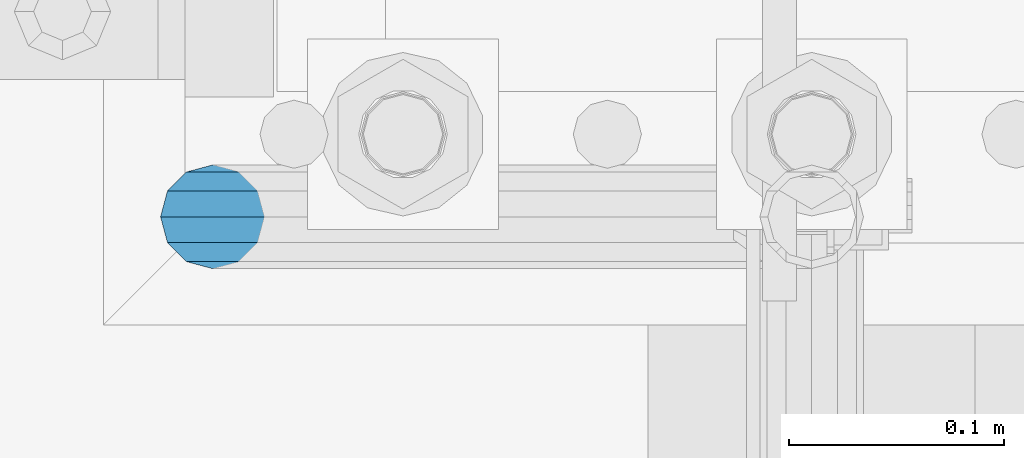
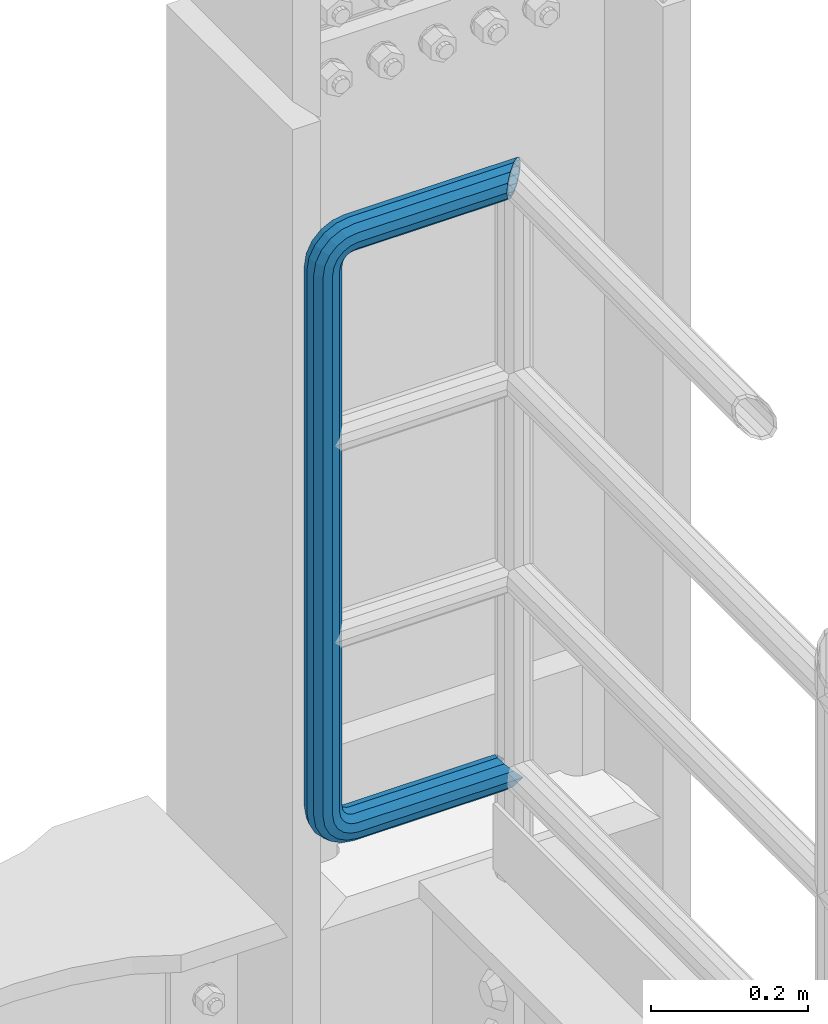
# One storey, part 1072 of 1876: 1 beam, 1 element without a shape of its own.
"""IFC2X3 building model written with IfcOpenShell, lengths in millimetres."""

from ifc_helpers import new_model, si_unit, frame, origin_with_axes, place, context, subcontext, project, spatial, faceted_brep, material, type_object, element, aggregate, save


model = new_model("IFC2X3")

# Units and contexts
model_context = context("Model", 3, precision=1e-05, world=origin_with_axes())
body_context = subcontext(model_context, "Body", "Model", "MODEL_VIEW")
ifc_project = project(units=[si_unit("LENGTHUNIT", "METRE", prefix="MILLI"), si_unit("AREAUNIT", "SQUARE_METRE"), si_unit("VOLUMEUNIT", "CUBIC_METRE"), si_unit("MASSUNIT", "GRAM", prefix="KILO"), si_unit("TIMEUNIT", "SECOND"), si_unit("PLANEANGLEUNIT", "RADIAN"), si_unit("SOLIDANGLEUNIT", "STERADIAN"), si_unit("THERMODYNAMICTEMPERATUREUNIT", "DEGREE_CELSIUS"), si_unit("LUMINOUSINTENSITYUNIT", "LUMEN")], contexts=[model_context])

# Site, building, storey
site_placement = place(None, origin_with_axes())
site = spatial("IfcSite", under=ifc_project, at=site_placement, CompositionType="ELEMENT")
building_placement = place(site_placement, origin_with_axes())
building = spatial("IfcBuilding", under=site, at=building_placement, Name="Undefined", CompositionType="ELEMENT")
storey_placement = place(building_placement, origin_with_axes())
storey = spatial("IfcBuildingStorey", under=building, at=storey_placement, Name="Undefined", CompositionType="ELEMENT", Elevation=0.0)

# Assembly, beam
assembly_placement = place(storey_placement, origin_with_axes())
assembly = element("IfcElementAssembly", 1, at=assembly_placement, inside=storey, Name="RAIL", AssemblyPlace="NOTDEFINED", PredefinedType="RIGID_FRAME")
ifc_material = material()
beam_type = type_object("IfcBeamType", Name="PIPE1-1/2SCH40", PredefinedType="NOTDEFINED")
beam_placement = place(assembly_placement, frame((7619.99999999999, 13499.7063, 14385.925), z_axis=(0.0, 0.0, 1.0), x_axis=(-1.0, 0.0, 0.0)))
beam = element("IfcBeam", 2, at=beam_placement, type_object=beam_type, material=ifc_material, Name="RAIL", ObjectType="PIPE1-1/2SCH40", context=body_context, shape_type="Brep", body=[
    faceted_brep([(1.20714750983051e-12, 24.1299999999974, -914.399963378906), (12.0650000000014, 20.8971929933159, -926.464963378905), (12.0650000000014, 20.8971929933177, -902.334963378908), (12.0650000000014, -20.8971929933195, -902.334963378908), (12.0650000000014, -20.8971929933195, -926.464963378905), (1.52133659548828e-12, -24.130000000001, -914.399963378906), (20.8971929933199, -12.0650000000023, -893.502770385589), (20.8971929933199, -12.0650000000005, -898.533841947723), (15.2545715621378, -17.7076214311819, -904.176463378906), (12.5151929933181, -20.4470000000019, -914.399963378906), (15.2545715621376, -17.7076214311819, -924.623463378906), (20.8971929933199, -12.0650000000005, -930.26608481009), (20.8971929933199, -12.0650000000023, -935.297156372224), (24.1300000000014, -1.81898940354586e-12, -934.846963378906), (24.1300000000014, -1.81898940354586e-12, -938.529963378907), (21.3906214311813, -10.2235000000019, -932.107584810088), (21.3906214311823, 10.2234999999982, -932.107584810088), (20.8971929933199, 12.0650000000005, -930.266084810086), (20.8971929933199, 12.0649999999987, -935.297156372224), (15.2545715621413, 17.7076214311783, -924.623463378906), (12.5151929933216, 20.4469999999983, -914.399963378906), (15.2545715621411, 17.7076214311783, -904.176463378906), (20.8971929933199, 12.0650000000005, -898.533841947727), (20.8971929933199, 12.0649999999987, -893.502770385589), (21.3906214311822, 10.2234999999982, -896.692341947724), (24.1300000000014, 0.0, -893.952963378906), (24.1300000000014, 0.0, -890.269963378905), (21.3906214311814, -10.2235000000019, -896.692341947724), (241.299995422363, 20.8971929933177, -12.0649999999987), (241.299995422363, 24.1299999999992, 0.0), (253.073542436527, 24.1299999999992, -1.86474665447167), (249.345252399393, 20.8971929933177, -13.3392435235728), (241.299995422363, 12.0650000000005, -20.8971929933177), (246.615954666858, 12.0650000000005, -21.7391582230448), (241.299995422363, 0.0, -24.130000000001), (245.616962362259, 0.0, -24.8137403926739), (241.299995422363, -12.0650000000005, -20.8971929933177), (246.615954666858, -12.0650000000005, -21.7391582230448), (241.299995422363, -20.8971929933177, -12.0649999999987), (249.345252399393, -20.8971929933177, -13.3392435235728), (241.299995422363, -24.1299999999992, 0.0), (253.073542436527, -24.1299999999992, -1.86474665447167), (241.299995422363, -20.8971929933177, 12.0649999999987), (256.801832473661, -20.8971929933177, 9.60975021462946), (241.299995422363, -12.0650000000005, 20.8971929933177), (259.531130206197, -12.0650000000005, 18.0096649141014), (241.299995422363, 0.0, 24.130000000001), (260.530122510796, 0.0, 21.084247083727), (241.299995422363, 12.0650000000005, 20.8971929933177), (259.531130206197, 12.0650000000005, 18.0096649141014), (241.299995422363, 20.8971929933177, 12.0649999999987), (256.801832473661, 20.8971929933177, 9.60975021462946), (291.464993896486, -20.8971929933177, -38.0999984741211), (279.399993896484, -24.1299999999992, -38.0999984741211), (279.399993896484, -24.1299999999992, -876.299964904785), (291.464993896484, -20.8971929933177, -876.299964904785), (267.334993896485, -20.8971929933177, -38.0999984741211), (267.334993896484, -20.8971929933177, -876.299964904785), (258.502800903167, -12.0650000000005, -38.0999984741211), (258.502800903166, -12.0650000000005, -876.299964904785), (255.269993896485, 0.0, -38.0999984741211), (255.269993896484, 0.0, -876.299964904785), (258.502800903167, 12.0650000000005, -38.0999984741211), (258.502800903166, 12.0650000000005, -876.299964904785), (267.334993896485, 20.8971929933177, -38.0999984741211), (267.334993896484, 20.8971929933177, -876.299964904785), (279.399993896485, 24.1299999999992, -38.0999984741211), (279.399993896484, 24.1299999999992, -876.299964904785), (291.464993896486, 20.8971929933177, -38.0999984741211), (291.464993896484, 20.8971929933177, -876.299964904785), (300.297186889804, 12.0650000000005, -38.0999984741211), (300.297186889803, 12.0650000000005, -876.299964904785), (303.529993896486, 0.0, -38.0999984741211), (303.529993896484, 0.0, -876.299964904785), (300.297186889804, -12.0650000000005, -38.0999984741211), (300.297186889803, -12.0650000000005, -876.299964904785), (297.409658810584, -12.0650000000005, -894.531099688622), (300.484240980214, 0.0, -895.53009199322), (297.409658810584, 12.0650000000005, -894.531099688622), (289.009744111112, 20.8971929933177, -891.801801956084), (277.535247242011, 24.1299999999992, -888.073511918952), (266.06075037291, 20.8971929933177, -884.345221881817), (257.660835673438, 12.0650000000005, -881.615924149282), (254.586253503809, 0.0, -880.616931844681), (257.660835673438, -12.0650000000005, -881.615924149282), (266.06075037291, -20.8971929933177, -884.345221881817), (277.535247242011, -24.130000000001, -888.073511918952), (289.009744111112, -20.8971929933195, -891.801801956084), (241.299995422363, -20.8971929933195, -902.334963378908), (241.299995422363, -12.0650000000005, -893.502770385589), (241.299995422363, -24.130000000001, -914.399963378906), (241.299995422364, -20.8971929933195, -926.464963378909), (241.299995422364, -12.0650000000005, -935.297156372228), (241.299995422364, -1.81898940354586e-12, -938.529963378911), (241.299995422364, 12.0649999999987, -935.297156372228), (241.299995422364, 20.8971929933177, -926.464963378909), (241.299995422364, 24.1299999999992, -914.39996337891), (241.299995422363, 20.8971929933177, -902.334963378908), (241.299995422363, 12.0649999999987, -893.502770385589), (241.299995422363, 0.0, -890.269963378909), (245.61696236226, 0.0, -889.586222986232), (246.615954666859, -12.0650000000005, -892.660805155861), (246.615954666859, 12.0649999999987, -892.660805155861), (249.345252399395, 20.8971929933177, -901.060719855333), (253.07354243653, 24.1299999999992, -912.535216724435), (256.801832473666, 20.8971929933177, -924.009713593536), (259.531130206202, 12.0649999999987, -932.409628293008), (260.530122510801, 0.0, -935.484210462637), (259.531130206201, -12.0650000000005, -932.409628293008), (256.801832473666, -20.8971929933195, -924.009713593536), (253.07354243653, -24.130000000001, -912.535216724435), (249.345252399395, -20.8971929933195, -901.060719855333), (251.411550782037, -12.0650000000005, -890.21732688968), (256.602983568912, -20.8971929933195, -897.362721118872), (249.511354500001, 0.0, -887.601931081743), (251.411550782037, 12.0650000000005, -890.21732688968), (256.602983568912, 20.8971929933177, -897.362721118872), (263.694612637823, 24.1299999999992, -907.123511156005), (270.786241706733, 20.8971929933177, -916.884301193139), (275.977674493594, 12.0649999999987, -924.029695422345), (277.877870775644, 0.0, -926.645091230272), (275.977674493608, -12.0650000000005, -924.029695422334), (270.786241706733, -20.8971929933195, -916.884301193139), (263.694612637823, -24.130000000001, -907.123511156005), (262.362751636451, -20.8971929933195, -891.602953051333), (272.123541673585, -24.130000000001, -898.694582120243), (255.217357407258, -12.0650000000005, -886.411520264461), (252.601961599318, 0.0, -884.511323982424), (255.217357407258, 12.0650000000005, -886.411520264461), (262.362751636451, 20.8971929933177, -891.602953051333), (272.123541673585, 24.1299999999992, -898.694582120243), (281.884331710718, 20.8971929933177, -905.786211189152), (289.029725939912, 12.0650000000005, -910.977643976028), (291.645121747852, 0.0, -912.877840258065), (289.029725939912, -12.0650000000005, -910.977643976028), (281.884331710718, -20.8971929933195, -905.786211189152), (289.009744111112, -20.8971929933177, -22.5981614228222), (297.409658810584, -12.0650000000005, -19.8688636902843), (277.535247242011, -24.1299999999992, -26.3264514599541), (266.060750372911, -20.8971929933177, -30.0547414970897), (257.660835673439, -12.0650000000005, -32.7840392296275), (254.58625350381, 0.0, -33.7830315342253), (257.660835673439, 12.0650000000005, -32.7840392296275), (266.060750372911, 20.8971929933177, -30.0547414970897), (277.535247242011, 24.1299999999992, -26.3264514599541), (289.009744111112, 20.8971929933177, -22.5981614228222), (297.409658810584, 12.0650000000005, -19.8688636902843), (300.484240980213, 0.0, -18.8698713856866), (289.029725939909, -12.0650000000005, -3.42231940287456), (291.645121747848, 0.0, -1.52212312084157), (281.884331710716, -20.8971929933177, -8.61375218975081), (272.123541673583, -24.1299999999992, -15.7053812586601), (262.362751636451, -20.8971929933177, -22.7970103275729), (255.217357407257, -12.0650000000005, -27.9884431144455), (252.601961599318, 0.0, -29.8886393964822), (255.217357407257, 12.0650000000005, -27.9884431144455), (262.362751636451, 20.8971929933177, -22.7970103275729), (272.123541673583, 24.1299999999992, -15.7053812586601), (281.884331710716, 20.8971929933177, -8.61375218975081), (289.029725939909, 12.0650000000005, -3.42231940287456), (277.877870775642, 0.0, 12.2451278513654), (275.977674493607, 12.0650000000005, 9.62973204342416), (275.977674493607, -12.0650000000005, 9.62973204342416), (270.786241706732, -20.8971929933177, 2.48433781423228), (263.694612637822, -24.1299999999992, -7.27645222290084), (256.602983568912, -20.8971929933177, -17.037242260034), (251.411550782037, -12.0650000000005, -24.1826364892258), (249.511354500002, 0.0, -26.7980322971671), (251.411550782037, 12.0650000000005, -24.1826364892258), (256.602983568912, 20.8971929933177, -17.037242260034), (263.694612637822, 24.1299999999992, -7.27645222290084), (270.786241706732, 20.8971929933177, 2.48433781423228), (24.1300000000047, 24.1299999999992, 0.0), (20.8971929933232, 20.8971929933177, 12.0649999999987), (12.0650000000041, 12.0650000000005, 20.8971929933177), (-1.45519152283669e-11, 0.0, 24.130000000001), (-12.0649999999951, -12.0650000000005, 20.8971929933177), (-20.8971929933141, -20.8971929933177, 12.0649999999987), (0.0, -24.1299999999992, 0.0), (-24.1299999999956, -24.1299999999992, 0.0), (-12.0650000000096, -20.8971929933177, -12.0649999999987), (12.0650000000064, -20.8971929933177, -12.0649999999987), (-20.8971929933141, -20.8971929933177, -12.0649999999987), (-12.0649999999951, -12.0650000000005, -20.8971929933177), (20.8971929933249, -12.0650000000005, -20.8971929933177), (-16.481093238739, -16.4810932387427, -16.4810997545756), (24.1300000000063, 0.0, -24.130000000001), (-1.45519152283669e-11, 0.0, -24.130000000001), (20.8971929933249, 12.0650000000005, -20.8971929933177), (12.0650000000041, 12.0650000000005, -20.8971929933177), (20.8971929933232, 20.8971929933177, -12.0649999999987), (16.481099754581, 16.4810997545774, -16.4810932387409), (241.299995422363, -17.7076214311801, 10.2235000000001), (241.299995422363, -20.4470000000001, 0.0), (-20.4469999999956, -20.4470000000001, 0.0), (-17.7076214311755, -17.7076214311801, 10.2235000000001), (241.299995422363, -17.7076214311801, -10.2235000000001), (-17.7076214311755, -17.7076214311801, -10.2235000000001), (241.299995422363, -10.2235000000001, -17.7076214311819), (-10.2234999999955, -10.2235000000001, -17.7076214311819), (241.299995422363, 0.0, -20.4470000000001), (-1.45519152283669e-11, 0.0, -20.4470000000001), (241.299995422363, 10.2235000000001, -17.7076214311819), (10.2235000000046, 10.2235000000001, -17.7076214311819), (241.299995422363, 17.7076214311801, -10.2235000000001), (17.7076214311846, 17.7076214311801, -10.2235000000001), (241.299995422363, 20.4470000000001, 0.0), (20.4470000000047, 20.4470000000001, 0.0), (241.299995422363, 0.0, 20.4470000000001), (241.299995422363, -10.2235000000001, 17.7076214311819), (-10.2234999999955, -10.2235000000001, 17.7076214311819), (-1.45519152283669e-11, 0.0, 20.4470000000001), (241.299995422363, 10.2235000000001, 17.7076214311819), (10.2235000000046, 10.2235000000001, 17.7076214311819), (241.299995422363, 17.7076214311801, 10.2235000000001), (17.7076214311846, 17.7076214311801, 10.2235000000001), (258.545498388721, -10.2235000000001, 14.9762020957387), (256.23277767852, -17.7076214311801, 7.85837963987069), (253.073542436527, -20.4470000000001, -1.86474665447167), (249.914307194535, -17.7076214311801, -11.5878729488177), (247.601586484334, -10.2235000000001, -18.7056954046857), (246.755071952542, 0.0, -21.31099924316), (247.601586484334, 10.2235000000001, -18.7056954046857), (249.914307194535, 17.7076214311801, -11.5878729488177), (253.073542436527, 20.4470000000001, -1.86474665447167), (256.23277767852, 17.7076214311801, 7.85837963987069), (258.545498388721, 10.2235000000001, 14.9762020957387), (259.392012920513, 0.0, 17.5815059342131), (275.713057691449, 0.0, 9.26551826108334), (274.10289136825, -10.2235000000001, 7.04931444488102), (274.10289136825, 10.2235000000001, 7.04931444488102), (269.703835164635, 17.7076214311801, 0.994533019089431), (263.694612637822, 20.4470000000001, -7.27645222290084), (257.685390111009, 17.7076214311801, -15.5474374648911), (253.286333907394, 10.2235000000001, -21.6022188906827), (251.676167584195, 0.0, -23.818422706885), (253.286333907394, -10.2235000000001, -21.6022188906827), (257.685390111009, -17.7076214311801, -15.5474374648911), (263.694612637822, -20.4470000000001, -7.27645222290084), (269.703835164635, -17.7076214311801, 0.994533019089431), (286.449308341364, -10.2235000000001, -5.29710252823133), (280.394526915574, -17.7076214311801, -9.69615873184739), (288.665512157566, 0.0, -3.68693620503473), (286.449308341364, 10.2235000000001, -5.29710252823133), (280.394526915574, 17.7076214311801, -9.69615873184739), (272.123541673583, 20.4470000000001, -15.7053812586601), (263.852556431592, 17.7076214311801, -21.7146037854764), (257.797775005802, 10.2235000000001, -26.1136599890888), (255.581571189601, 0.0, -27.723826312289), (257.797775005802, -10.2235000000001, -26.1136599890888), (263.852556431592, -17.7076214311801, -21.7146037854764), (272.123541673583, -20.4470000000001, -15.7053812586601), (287.258373536355, -17.7076214311801, -23.1672162179639), (277.535247242011, -20.4470000000001, -26.3264514599541), (294.376195992223, -10.2235000000001, -20.8544955077632), (296.981499830698, 0.0, -20.00798097597), (294.376195992223, 10.2235000000001, -20.8544955077632), (287.258373536355, 17.7076214311801, -23.1672162179639), (277.535247242011, 20.4470000000001, -26.3264514599541), (267.812120947668, 17.7076214311801, -29.485686701948), (260.6942984918, 10.2235000000001, -31.7984074121487), (258.088994653325, 0.0, -32.6449219439419), (260.6942984918, -10.2235000000001, -31.7984074121487), (267.812120947668, -17.7076214311801, -29.485686701948), (279.399993896484, -20.4470000000001, -38.0999984741211), (269.176493896485, -17.7076214311801, -38.0999984741211), (289.623493896486, -17.7076214311801, -38.0999984741211), (297.107615327666, -10.2235000000001, -38.0999984741211), (299.846993896486, 0.0, -38.0999984741211), (297.107615327666, 10.2235000000001, -38.0999984741211), (289.623493896486, 17.7076214311801, -38.0999984741211), (279.399993896485, 20.4470000000001, -38.0999984741211), (269.176493896485, 17.7076214311801, -38.0999984741211), (261.692372465305, 10.2235000000001, -38.0999984741211), (258.952993896485, 0.0, -38.0999984741211), (261.692372465305, -10.2235000000001, -38.0999984741211), (269.176493896484, -17.7076214311801, -876.299964904785), (261.692372465304, -10.2235000000001, -876.299964904785), (258.952993896484, 0.0, -876.299964904785), (261.692372465304, 10.2235000000001, -876.299964904785), (269.176493896484, 17.7076214311801, -876.299964904785), (279.399993896484, 20.4470000000001, -876.299964904785), (289.623493896484, 17.7076214311801, -876.299964904785), (297.107615327665, 10.2235000000001, -876.299964904785), (299.846993896484, 0.0, -876.299964904785), (297.107615327665, -10.2235000000001, -876.299964904785), (289.623493896484, -17.7076214311801, -876.299964904785), (279.399993896484, -20.4470000000001, -876.299964904785), (277.535247242011, -20.4470000000001, -888.073511918952), (267.812120947667, -17.7076214311801, -884.914276676958), (260.694298491799, -10.2235000000001, -882.601555966758), (258.088994653324, 0.0, -881.755041434964), (260.694298491799, 10.2235000000001, -882.601555966758), (267.812120947668, 17.7076214311801, -884.914276676958), (277.535247242011, 20.4470000000001, -888.073511918952), (287.258373536355, 17.7076214311801, -891.232747160942), (294.376195992223, 10.2235000000001, -893.545467871143), (296.981499830699, 0.0, -894.391982402936), (294.376195992223, -10.2235000000001, -893.545467871143), (287.258373536355, -17.7076214311801, -891.232747160942), (280.394526915577, -17.7076214311801, -904.703804647055), (272.123541673585, -20.4470000000001, -898.694582120243), (286.449308341367, -10.2235000000001, -909.102860850671), (288.665512157569, 0.0, -910.713027173868), (286.449308341367, 10.2235000000001, -909.102860850671), (280.394526915577, 17.7076214311801, -904.703804647055), (272.123541673585, 20.4470000000001, -898.694582120243), (263.852556431593, 17.7076214311801, -892.68535959343), (257.797775005802, 10.2235000000001, -888.286303389817), (255.581571189601, 0.0, -886.676137066617), (257.797775005802, -10.2235000000001, -888.286303389817), (263.852556431593, -17.7076214311801, -892.68535959343), (263.694612637823, -20.4470000000001, -907.123511156005), (257.685390111009, -17.7076214311801, -898.852525914015), (269.703835164636, -17.7076214311801, -915.394496397999), (274.102891368238, -10.2235000000001, -921.449277823798), (275.71305769145, 0.0, -923.66548163999), (274.102891368251, 10.2235000000001, -921.449277823787), (269.703835164636, 17.7076214311801, -915.394496397999), (263.694612637823, 20.4470000000001, -907.123511156005), (257.685390111009, 17.7076214311801, -898.852525914015), (253.286333907394, 10.2235000000001, -892.797744488227), (251.676167584195, 0.0, -890.581540672025), (253.286333907394, -10.2235000000001, -892.797744488227), (249.914307194537, -17.7076214311801, -902.812090430092), (247.601586484335, -10.2235000000001, -895.694267974224), (253.07354243653, -20.4470000000001, -912.535216724435), (256.232777678524, -17.7076214311819, -922.258343018777), (258.545498388725, -10.2235000000001, -929.376165474645), (259.392012920517, 0.0, -931.981469313119), (258.545498388725, 10.2235000000001, -929.376165474645), (256.232777678524, 17.7076214311801, -922.258343018777), (253.07354243653, 20.4470000000001, -912.535216724435), (249.914307194537, 17.7076214311801, -902.812090430092), (247.601586484335, 10.2235000000001, -895.694267974224), (246.755071952543, 0.0, -893.088964135746), (241.299995422363, -10.2235000000001, -896.692341947728), (241.299995422363, 0.0, -893.95296337891), (241.299995422363, -17.7076214311819, -904.17646337891), (241.299995422363, -20.4470000000001, -914.399963378906), (241.299995422364, -17.7076214311819, -924.62346337891), (241.299995422364, -10.2235000000001, -932.107584810088), (241.299995422364, -1.81898940354586e-12, -934.84696337891), (241.299995422364, 10.2234999999982, -932.107584810088), (241.299995422364, 17.7076214311801, -924.62346337891), (241.299995422364, 20.4470000000001, -914.39996337891), (241.299995422363, 17.7076214311801, -904.17646337891), (241.299995422363, 10.2235000000001, -896.692341947728)], [[[0, 1, 2]], [[3, 4, 5]], [[6, 7, 8, 9, 10, 11, 12, 4, 3]], [[13, 14, 12, 11, 15]], [[16, 17, 18, 14, 13]], [[2, 1, 18, 17, 19, 20, 21, 22, 23]], [[23, 22, 24, 25, 26]], [[26, 25, 27, 7, 6]], [[28, 29, 30, 31]], [[32, 28, 31, 33]], [[34, 32, 33, 35]], [[36, 34, 35, 37]], [[38, 36, 37, 39]], [[40, 38, 39, 41]], [[42, 40, 41, 43]], [[44, 42, 43, 45]], [[46, 44, 45, 47]], [[48, 46, 47, 49]], [[50, 48, 49, 51]], [[52, 53, 54, 55]], [[53, 56, 57, 54]], [[56, 58, 59, 57]], [[58, 60, 61, 59]], [[60, 62, 63, 61]], [[62, 64, 65, 63]], [[64, 66, 67, 65]], [[66, 68, 69, 67]], [[68, 70, 71, 69]], [[70, 72, 73, 71]], [[72, 74, 75, 73]], [[73, 75, 76, 77]], [[71, 73, 77, 78]], [[69, 71, 78, 79]], [[67, 69, 79, 80]], [[65, 67, 80, 81]], [[63, 65, 81, 82]], [[61, 63, 82, 83]], [[59, 61, 83, 84]], [[57, 59, 84, 85]], [[54, 57, 85, 86]], [[55, 54, 86, 87]], [[88, 89, 6, 3]], [[90, 88, 3, 5]], [[91, 90, 5, 4]], [[92, 91, 4, 12]], [[93, 92, 12, 14]], [[94, 93, 14, 18]], [[95, 94, 18, 1]], [[96, 95, 1, 0]], [[97, 96, 0, 2]], [[98, 97, 2, 23]], [[99, 98, 23, 26]], [[89, 99, 26, 6]], [[100, 99, 89, 101]], [[102, 98, 99, 100]], [[103, 97, 98, 102]], [[104, 96, 97, 103]], [[105, 95, 96, 104]], [[106, 94, 95, 105]], [[107, 93, 94, 106]], [[108, 92, 93, 107]], [[109, 91, 92, 108]], [[110, 90, 91, 109]], [[111, 88, 90, 110]], [[101, 89, 88, 111]], [[112, 101, 111, 113]], [[114, 100, 101, 112]], [[115, 102, 100, 114]], [[116, 103, 102, 115]], [[117, 104, 103, 116]], [[118, 105, 104, 117]], [[119, 106, 105, 118]], [[120, 107, 106, 119]], [[121, 108, 107, 120]], [[122, 109, 108, 121]], [[123, 110, 109, 122]], [[113, 111, 110, 123]], [[124, 113, 123, 125]], [[126, 112, 113, 124]], [[127, 114, 112, 126]], [[128, 115, 114, 127]], [[129, 116, 115, 128]], [[130, 117, 116, 129]], [[131, 118, 117, 130]], [[132, 119, 118, 131]], [[133, 120, 119, 132]], [[134, 121, 120, 133]], [[135, 122, 121, 134]], [[125, 123, 122, 135]], [[86, 125, 135, 87]], [[85, 124, 125, 86]], [[84, 126, 124, 85]], [[83, 127, 126, 84]], [[82, 128, 127, 83]], [[81, 129, 128, 82]], [[80, 130, 129, 81]], [[79, 131, 130, 80]], [[78, 132, 131, 79]], [[77, 133, 132, 78]], [[76, 134, 133, 77]], [[87, 135, 134, 76]], [[75, 55, 87, 76]], [[74, 52, 55, 75]], [[136, 52, 74, 137]], [[138, 53, 52, 136]], [[139, 56, 53, 138]], [[140, 58, 56, 139]], [[141, 60, 58, 140]], [[142, 62, 60, 141]], [[143, 64, 62, 142]], [[144, 66, 64, 143]], [[145, 68, 66, 144]], [[146, 70, 68, 145]], [[147, 72, 70, 146]], [[137, 74, 72, 147]], [[148, 137, 147, 149]], [[150, 136, 137, 148]], [[151, 138, 136, 150]], [[152, 139, 138, 151]], [[153, 140, 139, 152]], [[154, 141, 140, 153]], [[155, 142, 141, 154]], [[156, 143, 142, 155]], [[157, 144, 143, 156]], [[158, 145, 144, 157]], [[159, 146, 145, 158]], [[149, 147, 146, 159]], [[160, 149, 159, 161]], [[162, 148, 149, 160]], [[163, 150, 148, 162]], [[164, 151, 150, 163]], [[165, 152, 151, 164]], [[166, 153, 152, 165]], [[167, 154, 153, 166]], [[168, 155, 154, 167]], [[169, 156, 155, 168]], [[170, 157, 156, 169]], [[171, 158, 157, 170]], [[161, 159, 158, 171]], [[49, 161, 171, 51]], [[47, 160, 161, 49]], [[45, 162, 160, 47]], [[43, 163, 162, 45]], [[41, 164, 163, 43]], [[39, 165, 164, 41]], [[37, 166, 165, 39]], [[35, 167, 166, 37]], [[33, 168, 167, 35]], [[31, 169, 168, 33]], [[30, 170, 169, 31]], [[51, 171, 170, 30]], [[29, 50, 51, 30]], [[50, 29, 172, 173]], [[48, 50, 173, 174]], [[46, 48, 174, 175]], [[44, 46, 175, 176]], [[42, 44, 176, 177]], [[178, 40, 42, 177, 179]], [[180, 181, 38, 40, 178, 179, 182]], [[183, 184, 36, 38, 181, 180, 182, 185]], [[186, 34, 36, 184, 183, 187]], [[188, 32, 34, 186, 187, 189]], [[190, 28, 32, 188, 189, 191]], [[29, 28, 190, 172]], [[192, 193, 194, 195]], [[193, 196, 197, 194]], [[196, 198, 199, 197]], [[198, 200, 201, 199]], [[200, 202, 203, 201]], [[202, 204, 205, 203]], [[204, 206, 207, 205]], [[208, 209, 210, 211]], [[212, 208, 211, 213]], [[214, 212, 213, 215]], [[206, 214, 215, 207]], [[191, 189, 187, 183, 185, 182, 179, 177, 176, 175, 174, 173, 172, 190], [213, 211, 210, 195, 194, 197, 199, 201, 203, 205, 207, 215]], [[209, 192, 195, 210]], [[192, 209, 216, 217]], [[193, 192, 217, 218]], [[196, 193, 218, 219]], [[198, 196, 219, 220]], [[200, 198, 220, 221]], [[202, 200, 221, 222]], [[204, 202, 222, 223]], [[206, 204, 223, 224]], [[214, 206, 224, 225]], [[212, 214, 225, 226]], [[208, 212, 226, 227]], [[209, 208, 227, 216]], [[227, 228, 229, 216]], [[226, 230, 228, 227]], [[225, 231, 230, 226]], [[224, 232, 231, 225]], [[223, 233, 232, 224]], [[222, 234, 233, 223]], [[221, 235, 234, 222]], [[220, 236, 235, 221]], [[219, 237, 236, 220]], [[218, 238, 237, 219]], [[217, 239, 238, 218]], [[216, 229, 239, 217]], [[229, 240, 241, 239]], [[228, 242, 240, 229]], [[230, 243, 242, 228]], [[231, 244, 243, 230]], [[232, 245, 244, 231]], [[233, 246, 245, 232]], [[234, 247, 246, 233]], [[235, 248, 247, 234]], [[236, 249, 248, 235]], [[237, 250, 249, 236]], [[238, 251, 250, 237]], [[239, 241, 251, 238]], [[241, 252, 253, 251]], [[240, 254, 252, 241]], [[242, 255, 254, 240]], [[243, 256, 255, 242]], [[244, 257, 256, 243]], [[245, 258, 257, 244]], [[246, 259, 258, 245]], [[247, 260, 259, 246]], [[248, 261, 260, 247]], [[249, 262, 261, 248]], [[250, 263, 262, 249]], [[251, 253, 263, 250]], [[253, 264, 265, 263]], [[252, 266, 264, 253]], [[254, 267, 266, 252]], [[255, 268, 267, 254]], [[256, 269, 268, 255]], [[257, 270, 269, 256]], [[258, 271, 270, 257]], [[259, 272, 271, 258]], [[260, 273, 272, 259]], [[261, 274, 273, 260]], [[262, 275, 274, 261]], [[263, 265, 275, 262]], [[275, 265, 276, 277]], [[274, 275, 277, 278]], [[273, 274, 278, 279]], [[272, 273, 279, 280]], [[271, 272, 280, 281]], [[270, 271, 281, 282]], [[269, 270, 282, 283]], [[268, 269, 283, 284]], [[267, 268, 284, 285]], [[266, 267, 285, 286]], [[264, 266, 286, 287]], [[265, 264, 287, 276]], [[276, 287, 288, 289]], [[277, 276, 289, 290]], [[278, 277, 290, 291]], [[279, 278, 291, 292]], [[280, 279, 292, 293]], [[281, 280, 293, 294]], [[282, 281, 294, 295]], [[283, 282, 295, 296]], [[284, 283, 296, 297]], [[285, 284, 297, 298]], [[286, 285, 298, 299]], [[287, 286, 299, 288]], [[299, 300, 301, 288]], [[298, 302, 300, 299]], [[297, 303, 302, 298]], [[296, 304, 303, 297]], [[295, 305, 304, 296]], [[294, 306, 305, 295]], [[293, 307, 306, 294]], [[292, 308, 307, 293]], [[291, 309, 308, 292]], [[290, 310, 309, 291]], [[289, 311, 310, 290]], [[288, 301, 311, 289]], [[301, 312, 313, 311]], [[300, 314, 312, 301]], [[302, 315, 314, 300]], [[303, 316, 315, 302]], [[304, 317, 316, 303]], [[305, 318, 317, 304]], [[306, 319, 318, 305]], [[307, 320, 319, 306]], [[308, 321, 320, 307]], [[309, 322, 321, 308]], [[310, 323, 322, 309]], [[311, 313, 323, 310]], [[313, 324, 325, 323]], [[312, 326, 324, 313]], [[314, 327, 326, 312]], [[315, 328, 327, 314]], [[316, 329, 328, 315]], [[317, 330, 329, 316]], [[318, 331, 330, 317]], [[319, 332, 331, 318]], [[320, 333, 332, 319]], [[321, 334, 333, 320]], [[322, 335, 334, 321]], [[323, 325, 335, 322]], [[325, 336, 337, 335]], [[324, 338, 336, 325]], [[326, 339, 338, 324]], [[327, 340, 339, 326]], [[328, 341, 340, 327]], [[329, 342, 341, 328]], [[330, 343, 342, 329]], [[331, 344, 343, 330]], [[332, 345, 344, 331]], [[333, 346, 345, 332]], [[334, 347, 346, 333]], [[335, 337, 347, 334]], [[347, 337, 25, 24]], [[21, 346, 347, 24, 22]], [[345, 346, 21, 20]], [[344, 345, 20, 19]], [[343, 344, 19, 17, 16]], [[342, 343, 16, 13]], [[341, 342, 13, 15]], [[10, 340, 341, 15, 11]], [[339, 340, 10, 9]], [[338, 339, 9, 8]], [[336, 338, 8, 7, 27]], [[337, 336, 27, 25]]]),
])
aggregate(assembly, [beam])

save(model, "model.ifc")
